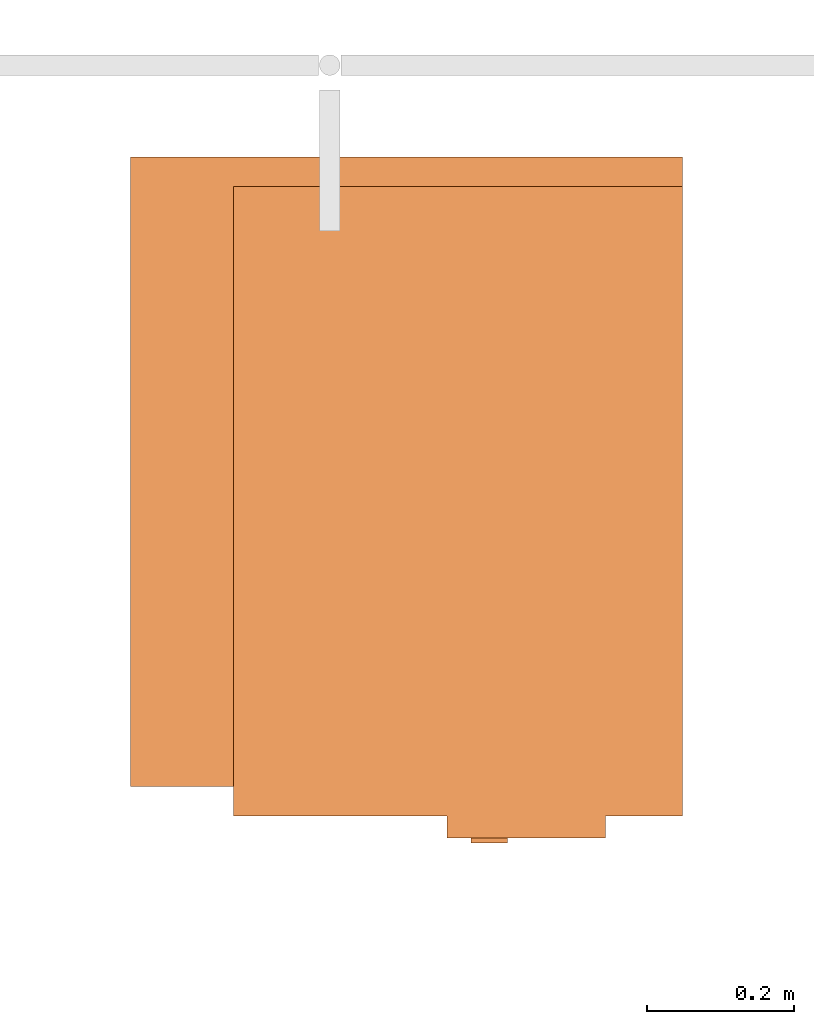
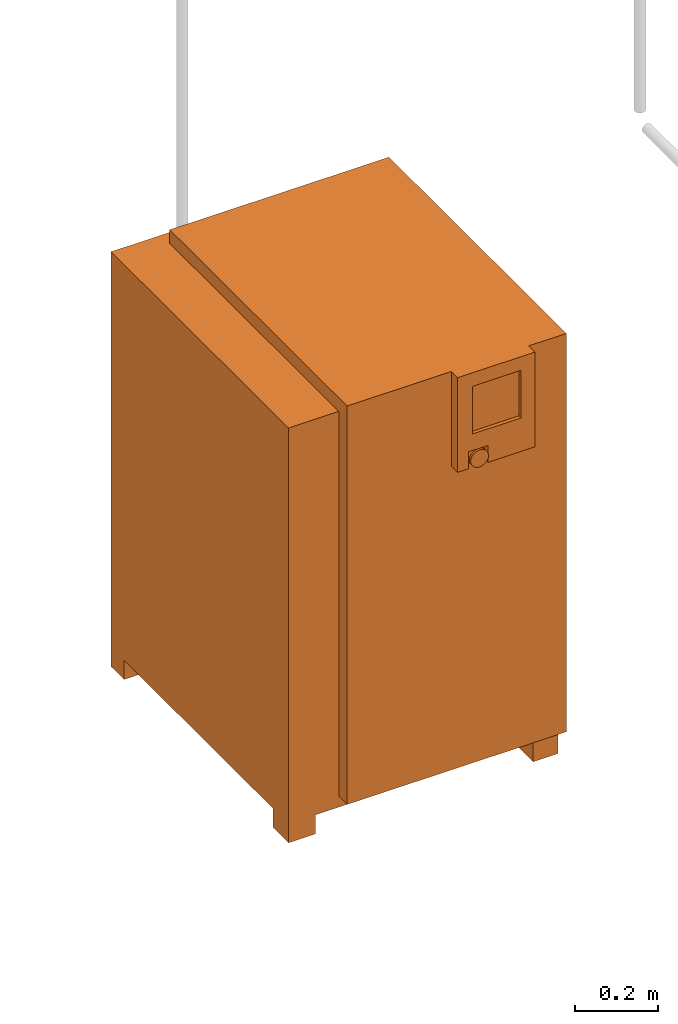
# One storey, part 326 of 331: 1 proxy.
"""IFC2X3 building model written with IfcOpenShell, lengths in millimetres."""

from ifc_helpers import new_model, entity, si_unit, converted_unit, derived_unit, direction, frame, origin, place, context, subcontext, project, spatial, faceted_brep, source, transform, mapped, material, material_list, type_object, type_shapes, element, save


model = new_model("IFC2X3")

# Units and contexts
model_context = context("Model", 3, precision=0.01, world=origin(), true_north=direction((6.12303176911189e-17, 1.0)))
body_context = subcontext(model_context, "Body", "Model", "MODEL_VIEW")
ifc_project = project(units=[si_unit("LENGTHUNIT", "METRE", prefix="MILLI"), si_unit("AREAUNIT", "SQUARE_METRE"), si_unit("VOLUMEUNIT", "CUBIC_METRE"), converted_unit("PLANEANGLEUNIT", "DEGREE", entity("IfcRatioMeasure", 0.0174532925199433), si_unit("PLANEANGLEUNIT", "RADIAN"), dimensions=[0, 0, 0, 0, 0, 0, 0]), si_unit("MASSUNIT", "GRAM", prefix="KILO"), derived_unit("MASSDENSITYUNIT", [(si_unit("MASSUNIT", "GRAM", prefix="KILO"), 1), (si_unit("LENGTHUNIT", "METRE"), -3)]), derived_unit("MOMENTOFINERTIAUNIT", [(si_unit("LENGTHUNIT", "METRE"), 4)]), si_unit("TIMEUNIT", "SECOND"), si_unit("FREQUENCYUNIT", "HERTZ"), si_unit("THERMODYNAMICTEMPERATUREUNIT", "DEGREE_CELSIUS"), derived_unit("THERMALTRANSMITTANCEUNIT", [(si_unit("MASSUNIT", "GRAM", prefix="KILO"), 1), (si_unit("THERMODYNAMICTEMPERATUREUNIT", "KELVIN"), -1), (si_unit("TIMEUNIT", "SECOND"), -3)]), derived_unit("VOLUMETRICFLOWRATEUNIT", [(si_unit("LENGTHUNIT", "METRE"), 3), (si_unit("TIMEUNIT", "SECOND"), -1)]), derived_unit("MASSFLOWRATEUNIT", [(si_unit("MASSUNIT", "GRAM", prefix="KILO"), 1), (si_unit("TIMEUNIT", "SECOND"), -1)]), derived_unit("ROTATIONALFREQUENCYUNIT", [(si_unit("TIMEUNIT", "SECOND"), -1)]), si_unit("ELECTRICCURRENTUNIT", "AMPERE"), si_unit("ELECTRICVOLTAGEUNIT", "VOLT"), si_unit("POWERUNIT", "WATT"), si_unit("FORCEUNIT", "NEWTON", prefix="KILO"), si_unit("ILLUMINANCEUNIT", "LUX"), si_unit("LUMINOUSFLUXUNIT", "LUMEN"), si_unit("LUMINOUSINTENSITYUNIT", "CANDELA"), derived_unit("USERDEFINED", [(si_unit("MASSUNIT", "GRAM", prefix="KILO"), -1), (si_unit("LENGTHUNIT", "METRE"), -2), (si_unit("TIMEUNIT", "SECOND"), 3), (si_unit("LUMINOUSFLUXUNIT", "LUMEN"), 1)]), derived_unit("LINEARVELOCITYUNIT", [(si_unit("LENGTHUNIT", "METRE"), 1), (si_unit("TIMEUNIT", "SECOND"), -1)]), si_unit("PRESSUREUNIT", "PASCAL"), derived_unit("USERDEFINED", [(si_unit("LENGTHUNIT", "METRE"), -2), (si_unit("MASSUNIT", "GRAM", prefix="KILO"), 1), (si_unit("TIMEUNIT", "SECOND"), -2)]), derived_unit("LINEARFORCEUNIT", [(si_unit("MASSUNIT", "GRAM", prefix="KILO"), 1), (si_unit("LENGTHUNIT", "METRE"), 1), (si_unit("TIMEUNIT", "SECOND"), -2), (si_unit("LENGTHUNIT", "METRE"), -1)]), derived_unit("PLANARFORCEUNIT", [(si_unit("MASSUNIT", "GRAM", prefix="KILO"), 1), (si_unit("LENGTHUNIT", "METRE"), 1), (si_unit("TIMEUNIT", "SECOND"), -2), (si_unit("LENGTHUNIT", "METRE"), -2)])], contexts=[model_context])

# Site, building, storey
site_placement = place(None, frame((0.0, -0.00077364408347762, 0.0)))
site = spatial("IfcSite", under=ifc_project, at=site_placement, CompositionType="ELEMENT")
building_placement = place(site_placement, origin())
building = spatial("IfcBuilding", under=site, at=building_placement, CompositionType="ELEMENT")
storey_placement = place(building_placement, origin())
storey = spatial("IfcBuildingStorey", under=building, at=storey_placement, CompositionType="ELEMENT", Elevation=0.0)

# Proxy
ifc_material_1 = material()
ifc_material_2 = material()
ifc_material_3 = material()
ifc_material_list = material_list([ifc_material_1, ifc_material_2, ifc_material_3])
building_element_proxy_type = type_object("IfcBuildingElementProxyType", Name="SK 22:SK 22", PredefinedType="NOTDEFINED", material=ifc_material_1)
shared_shape = source(origin(), body_context, "Body", "Brep", [
    faceted_brep([(-407.500000000001, 235.0, 1220.0), (447.499999999999, 235.0, 1220.0), (447.5, 375.0, 1220.0), (-407.5, 375.0, 1220.0), (447.5, 375.0, 0.0), (447.5, 300.0, 0.0), (384.634472919975, 300.0, 0.0), (384.634472919975, 375.0, 0.0), (-407.500000000001, 235.0, 56.089418150774), (447.499999999999, 235.0, 56.089418150774), (447.499999999999, 300.0, 56.089418150774), (384.634472919975, 375.0, 56.089418150774), (-332.5, 375.0, 56.089418150774), (-332.5, 375.0, 0.0), (-407.5, 375.0, 0.0), (-407.5, 300.0, 0.0), (-407.5, 300.0, 56.089418150774), (-332.5, 300.0, 56.089418150774), (384.634472919975, 300.0, 56.089418150774), (-332.5, 300.0, 0.0)], [[[0, 1, 2, 3]], [[4, 5, 6, 7]], [[1, 0, 8, 9]], [[2, 1, 9, 10, 5, 4]], [[3, 2, 4, 7, 11, 12, 13, 14]], [[0, 3, 14, 15, 16, 8]], [[10, 9, 8, 16, 17, 12, 11, 18]], [[5, 10, 18, 6]], [[12, 17, 19, 13]], [[18, 11, 7, 6]], [[16, 15, 19, 17]], [[15, 14, 13, 19]]]),
    faceted_brep([(-483.897349584666, -118.970476127563, 982.237770655706), (-483.897349584666, -125.0, 984.735281218321), (-483.897349584666, -130.177669529664, 988.708246783269), (-483.897349584666, -134.150635094611, 993.885916312932), (-483.897349584666, -136.648145657227, 999.915440185369), (-483.897349584666, -137.5, 1006.38591631293), (-483.897349584666, -136.648145657227, 1012.8563924405), (-483.897349584666, -134.150635094611, 1018.88591631293), (-483.897349584666, -130.177669529664, 1024.0635858426), (-483.897349584666, -125.0, 1028.03655140754), (-483.897349584666, -118.970476127563, 1030.53406197016), (-483.897349584666, -112.5, 1031.38591631293), (-483.897349584666, -106.029523872437, 1030.53406197016), (-483.897349584666, -100.0, 1028.03655140754), (-483.897349584666, -94.8223304703364, 1024.0635858426), (-483.897349584666, -90.8493649053891, 1018.88591631293), (-483.897349584666, -88.3518543427734, 1012.8563924405), (-483.897349584666, -87.5, 1006.38591631293), (-483.897349584666, -88.3518543427733, 999.915440185369), (-483.897349584666, -90.849364905389, 993.885916312933), (-483.897349584666, -94.8223304703363, 988.708246783269), (-483.897349584666, -100.0, 984.735281218321), (-483.897349584666, -106.029523872437, 982.237770655706), (-483.897349584666, -112.5, 981.385916312932), (-477.500000000001, -118.970476127563, 1030.53406197016), (-477.500000000001, -125.0, 1028.03655140754), (-477.500000000001, -130.177669529664, 1024.0635858426), (-477.500000000001, -134.150635094611, 1018.88591631293), (-477.500000000001, -136.648145657227, 1012.8563924405), (-477.500000000001, -137.5, 1006.38591631293), (-477.500000000001, -136.648145657227, 999.915440185369), (-477.500000000001, -134.150635094611, 993.885916312932), (-477.500000000001, -130.177669529664, 988.708246783269), (-477.500000000001, -125.0, 984.735281218321), (-477.500000000001, -118.970476127563, 982.237770655706), (-477.500000000001, -112.5, 981.385916312932), (-477.500000000001, -106.029523872437, 982.237770655706), (-477.500000000001, -100.0, 984.735281218321), (-477.500000000001, -94.8223304703363, 988.708246783269), (-477.500000000001, -90.849364905389, 993.885916312933), (-477.500000000001, -88.3518543427733, 999.915440185369), (-477.500000000001, -87.5000000000001, 1006.38591631293), (-477.500000000001, -88.3518543427734, 1012.8563924405), (-477.500000000001, -90.8493649053891, 1018.88591631293), (-477.500000000001, -94.8223304703364, 1024.0635858426), (-477.500000000001, -100.0, 1028.03655140754), (-477.500000000001, -106.029523872437, 1030.53406197016), (-477.500000000001, -112.5, 1031.38591631293)], [[[0, 1, 2, 3, 4, 5, 6, 7, 8, 9, 10, 11, 12, 13, 14, 15, 16, 17, 18, 19, 20, 21, 22, 23]], [[24, 25, 26, 27, 28, 29, 30, 31, 32, 33, 34, 35, 36, 37, 38, 39, 40, 41, 42, 43, 44, 45, 46, 47]], [[40, 18, 17, 41]], [[39, 19, 18, 40]], [[21, 20, 38, 37]], [[39, 38, 20, 19]], [[22, 21, 37, 36]], [[23, 22, 36, 35]], [[34, 0, 23, 35]], [[33, 1, 0, 34]], [[3, 2, 32, 31]], [[33, 32, 2, 1]], [[4, 3, 31, 30]], [[5, 4, 30, 29]], [[28, 6, 5, 29]], [[27, 7, 6, 28]], [[9, 8, 26, 25]], [[27, 26, 8, 7]], [[10, 9, 25, 24]], [[11, 10, 24, 47]], [[46, 12, 11, 47]], [[45, 13, 12, 46]], [[15, 14, 44, 43]], [[45, 44, 14, 13]], [[16, 15, 43, 42]], [[17, 16, 42, 41]]]),
    faceted_brep([(-477.500000000001, -55.0, 1260.0), (-477.500000000001, -270.0, 1260.0), (-447.500000000001, -270.0, 1260.0), (-447.500000000001, -55.0, 1260.0), (-477.500000000001, -55.0, 981.385916312933), (-447.500000000001, -55.0, 981.385916312933), (-447.500000000001, -270.0, 981.385916312933), (-477.500000000001, -270.0, 981.385916312933), (-477.500000000001, -140.0, 981.385916312933), (-457.500000000001, -140.0, 981.385916312933), (-457.500000000001, -85.0, 981.385916312933), (-477.500000000001, -85.0, 981.385916312933), (-477.500000000001, -85.0, 1031.38591631293), (-477.500000000001, -140.0, 1031.38591631293), (-477.500000000001, -96.0179774809665, 1220.0), (-477.500000000001, -231.017977480966, 1220.0), (-477.500000000001, -231.017977480966, 1080.0), (-477.500000000001, -96.0179774809665, 1080.0), (-467.500000000001, -231.017977480966, 1220.0), (-467.500000000001, -96.0179774809666, 1220.0), (-467.500000000001, -96.0179774809665, 1080.0), (-467.500000000001, -231.017977480966, 1080.0), (-457.500000000001, -85.0, 1031.38591631293), (-457.500000000001, -140.0, 1031.38591631293)], [[[0, 1, 2, 3]], [[4, 5, 6, 7, 8, 9, 10, 11]], [[1, 0, 4, 11, 12, 13, 8, 7], [14, 15, 16, 17]], [[2, 1, 7, 6]], [[3, 2, 6, 5]], [[0, 3, 5, 4]], [[18, 19, 20, 21]], [[19, 18, 15, 14]], [[20, 19, 14, 17]], [[21, 20, 17, 16]], [[18, 21, 16, 15]], [[22, 10, 9, 23]], [[10, 22, 12, 11]], [[23, 9, 8, 13]], [[22, 23, 13, 12]]]),
    faceted_brep([(447.499999999998, -375.0, 1220.0), (447.499999999999, 235.0, 1220.0), (-407.500000000001, 235.0, 1220.0), (-407.500000000001, -342.939909824343, 1220.0), (407.5, -342.939909824343, 1220.0), (407.5, -375.0, 1220.0), (447.499999999998, -305.288454892349, 0.0), (447.499999999998, -375.0, 0.0), (384.634472919974, -375.0, 0.0), (384.634472919974, -305.288454892349, 0.0), (407.499999999998, -375.0, 88.1437175093115), (-407.500000000001, -375.0, 88.1437175093142), (-407.500000000001, -375.0, 0.0), (-332.500000000001, -375.0, 0.0), (-332.500000000001, -375.0, 56.089418150774), (384.634472919974, -375.0, 56.089418150774), (447.499999999998, -305.288454892349, 56.089418150774), (447.499999999999, 235.0, 56.089418150774), (-407.500000000001, 235.0, 56.089418150774), (-407.500000000001, -305.288454892347, 56.089418150774), (-407.500000000001, -305.288454892347, 0.0), (-407.500000000001, -342.939909824343, 88.1437175093142), (407.499999999998, -342.939909824343, 88.1437175093115), (384.634472919974, -305.288454892349, 56.089418150774), (-332.500000000001, -305.288454892347, 56.089418150774), (-332.500000000001, -305.288454892347, 0.0)], [[[0, 1, 2, 3, 4, 5]], [[6, 7, 8, 9]], [[7, 0, 5, 10, 11, 12, 13, 14, 15, 8]], [[1, 0, 7, 6, 16, 17]], [[2, 1, 17, 18]], [[3, 2, 18, 19, 20, 12, 11, 21]], [[21, 22, 4, 3]], [[22, 21, 11, 10]], [[4, 22, 10, 5]], [[17, 16, 23, 15, 14, 24, 19, 18]], [[20, 19, 24, 25]], [[24, 14, 13, 25]], [[15, 23, 9, 8]], [[16, 6, 9, 23]], [[12, 20, 25, 13]]]),
    faceted_brep([(407.5, 235.0, 1260.0), (-447.5, 235.0, 1260.0), (-447.500000000001, -375.0, 1260.0), (407.499999999998, -375.0, 1260.0), (-447.500000000001, -375.0, 88.1437175093128), (-447.5, 235.0, 88.1437175093128), (407.5, 235.0, 88.1437175093128), (407.499999999998, -342.939909824343, 88.1437175093128), (-407.5, -342.939909824343, 88.1437175093128), (-407.5, -375.0, 88.1437175093128), (-407.499999999999, -375.0, 1220.0), (407.499999999998, -375.0, 1220.0), (407.499999999998, -342.939909824343, 1220.0), (-407.499999999999, -342.939909824343, 1220.0)], [[[0, 1, 2, 3]], [[4, 5, 6, 7, 8, 9]], [[1, 0, 6, 5]], [[2, 1, 5, 4]], [[3, 2, 4, 9, 10, 11]], [[0, 3, 11, 12, 7, 6]], [[12, 13, 8, 7]], [[13, 12, 11, 10]], [[8, 13, 10, 9]]]),
])
type_shapes(building_element_proxy_type, [shared_shape])
proxy_placement = place(storey_placement, frame((48805.003616884, -1227.50010169851, -700.0), z_axis=(0.0, 0.0, 1.0), x_axis=(0.0, 1.0, 0.0)))
element("IfcBuildingElementProxy", 1, at=proxy_placement, inside=storey, type_object=building_element_proxy_type, material=ifc_material_list, Name="SK 22:SK 22", ObjectType="SK 22:SK 22", context=body_context, shape_type="MappedRepresentation", body=[
    mapped(shared_shape, transform((0.0, 0.0, 0.0), scale=1.0)),
])

save(model, "model.ifc")
